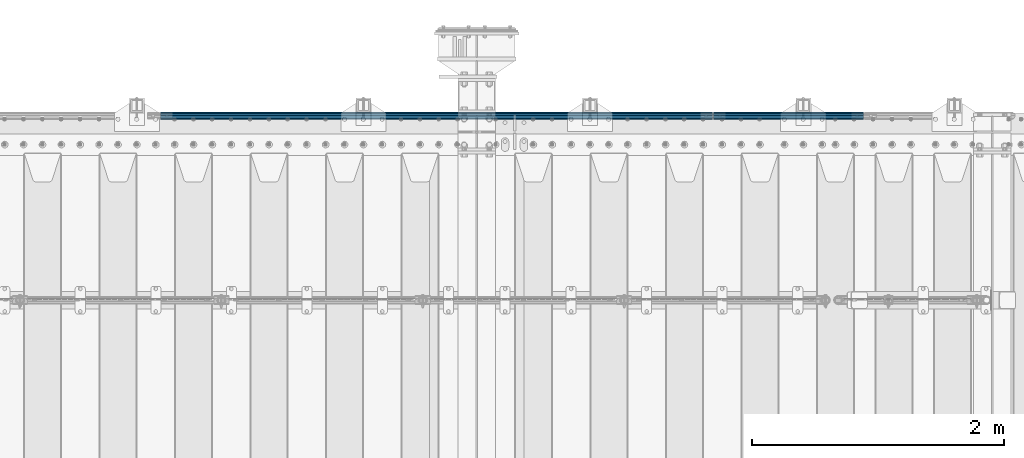
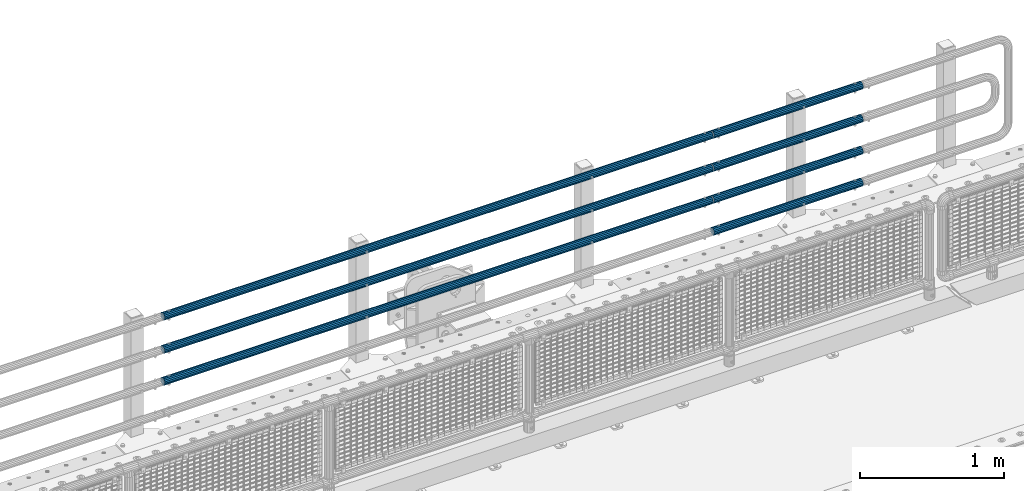
# One storey, part 108 of 208: 7 beams.
"""IFC2X3 building model written with IfcOpenShell, lengths in millimetres."""

from ifc_helpers import new_model, si_unit, frame, origin_with_axes, place, context, subcontext, project, spatial, faceted_brep, material, type_object, element, save


model = new_model("IFC2X3")

# Units and contexts
model_context = context("Model", 3, precision=1e-05, world=origin_with_axes())
body_context = subcontext(model_context, "Body", "Model", "MODEL_VIEW")
ifc_project = project(units=[si_unit("LENGTHUNIT", "METRE", prefix="MILLI"), si_unit("AREAUNIT", "SQUARE_METRE"), si_unit("VOLUMEUNIT", "CUBIC_METRE"), si_unit("MASSUNIT", "GRAM", prefix="KILO"), si_unit("TIMEUNIT", "SECOND"), si_unit("PLANEANGLEUNIT", "RADIAN"), si_unit("SOLIDANGLEUNIT", "STERADIAN"), si_unit("THERMODYNAMICTEMPERATUREUNIT", "DEGREE_CELSIUS"), si_unit("LUMINOUSINTENSITYUNIT", "LUMEN")], contexts=[model_context])

# Site, building, storey
site_placement = place(None, origin_with_axes())
site = spatial("IfcSite", under=ifc_project, at=site_placement, CompositionType="ELEMENT")
building_placement = place(site_placement, origin_with_axes())
building = spatial("IfcBuilding", under=site, at=building_placement, Name="Standard", CompositionType="ELEMENT")
storey_placement = place(building_placement, origin_with_axes())
storey = spatial("IfcBuildingStorey", under=building, at=storey_placement, Name="Undefined", CompositionType="ELEMENT", Elevation=0.0)

# Beams
ifc_material = material()
beam_type = type_object("IfcBeamType", PredefinedType="NOTDEFINED")
beam_1_placement = place(storey_placement, frame((-28328.0000000001, 6129.85000000019, 420.149999999728), z_axis=(0.0, 0.0, -1.0), x_axis=(-1.0, 0.0, 0.0)))
element("IfcBeam", 1, at=beam_1_placement, inside=storey, type_object=beam_type, material=ifc_material, context=body_context, shape_type="Brep", body=[
    faceted_brep([(0.0, -26.5500000000002, 0.0), (0.0, -24.5290015881747, 10.1602451292931), (4384.0, -24.5290015881747, 10.1602451292931), (4384.0, -26.5500000000002, 0.0), (0.0, -18.7736850405026, 18.7736850405028), (4384.0, -18.7736850405026, 18.7736850405028), (0.0, -10.1602451292929, 24.5290015881747), (4384.0, -10.1602451292929, 24.5290015881747), (0.0, 0.0, 26.55), (4384.0, 0.0, 26.55), (0.0, 10.1602451292929, 24.5290015881747), (4384.0, 10.1602451292929, 24.5290015881747), (0.0, 18.7736850405026, 18.7736850405028), (4384.0, 18.7736850405026, 18.7736850405028), (0.0, 24.5290015881747, 10.1602451292931), (4384.0, 24.5290015881747, 10.1602451292931), (0.0, 26.5500000000002, 0.0), (4384.0, 26.5500000000002, 0.0), (0.0, 24.5290015881747, -10.1602451292931), (4384.0, 24.5290015881747, -10.1602451292931), (0.0, 18.7736850405026, -18.7736850405028), (4384.0, 18.7736850405026, -18.7736850405028), (0.0, 10.1602451292929, -24.5290015881747), (4384.0, 10.1602451292929, -24.5290015881747), (0.0, 0.0, -26.55), (4384.0, 0.0, -26.55), (0.0, -10.1602451292929, -24.5290015881747), (4384.0, -10.1602451292929, -24.5290015881747), (0.0, -18.7736850405026, -18.7736850405028), (4384.0, -18.7736850405026, -18.7736850405028), (0.0, -24.5290015881747, -10.1602451292931), (4384.0, -24.5290015881747, -10.1602451292931), (0.0, -30.1499999999996, 0.0), (0.0, -27.8549679052148, -11.5379054858058), (4384.0, -27.8549679052148, -11.5379054858075), (4384.0, -30.1499999999996, 0.0), (0.0, -21.3192694527743, -21.3192694527752), (4384.0, -21.3192694527743, -21.3192694527744), (0.0, -11.5379054858076, -27.8549679052157), (4384.0, -11.5379054858076, -27.8549679052153), (0.0, 0.0, -30.1500000000015), (4384.0, 0.0, -30.15), (0.0, 11.5379054858076, -27.8549679052157), (4384.0, 11.5379054858076, -27.8549679052153), (0.0, 21.3192694527743, -21.3192694527752), (4384.0, 21.3192694527743, -21.3192694527744), (0.0, 27.8549679052157, -11.5379054858058), (4384.0, 27.8549679052157, -11.5379054858074), (0.0, 30.1499999999996, 0.0), (4384.0, 30.1499999999996, 0.0), (0.0, 27.8549679052157, 11.5379054858058), (4384.0, 27.8549679052157, 11.5379054858075), (0.0, 21.3192694527743, 21.3192694527752), (4384.0, 21.3192694527743, 21.3192694527744), (0.0, 11.5379054858076, 27.8549679052157), (4384.0, 11.5379054858076, 27.8549679052153), (0.0, 0.0, 30.1500000000015), (4384.0, 0.0, 30.15), (0.0, -11.5379054858076, 27.8549679052157), (4384.0, -11.5379054858076, 27.8549679052153), (0.0, -21.3192694527743, 21.3192694527752), (4384.0, -21.3192694527743, 21.3192694527744), (0.0, -27.8549679052157, 11.5379054858058), (4384.0, -27.8549679052157, 11.5379054858075)], [[[0, 1, 2, 3]], [[1, 4, 5, 2]], [[4, 6, 7, 5]], [[6, 8, 9, 7]], [[8, 10, 11, 9]], [[10, 12, 13, 11]], [[12, 14, 15, 13]], [[14, 16, 17, 15]], [[16, 18, 19, 17]], [[18, 20, 21, 19]], [[20, 22, 23, 21]], [[22, 24, 25, 23]], [[24, 26, 27, 25]], [[26, 28, 29, 27]], [[28, 30, 31, 29]], [[30, 0, 3, 31]], [[32, 33, 34, 35]], [[33, 36, 37, 34]], [[36, 38, 39, 37]], [[38, 40, 41, 39]], [[40, 42, 43, 41]], [[42, 44, 45, 43]], [[44, 46, 47, 45]], [[46, 48, 49, 47]], [[48, 50, 51, 49]], [[50, 52, 53, 51]], [[52, 54, 55, 53]], [[54, 56, 57, 55]], [[56, 58, 59, 57]], [[58, 60, 61, 59]], [[60, 62, 63, 61]], [[62, 32, 35, 63]], [[37, 39, 41, 43, 45, 47, 49, 51, 53, 55, 57, 59, 61, 63, 35, 34], [5, 7, 9, 11, 13, 15, 17, 19, 21, 23, 25, 27, 29, 31, 3, 2]], [[62, 60, 58, 56, 54, 52, 50, 48, 46, 44, 42, 40, 38, 36, 33, 32], [30, 28, 26, 24, 22, 20, 18, 16, 14, 12, 10, 8, 6, 4, 1, 0]]]),
])
beam_2_placement = place(storey_placement, frame((-28328.0000000001, 6129.85000000019, 969.849999999725), z_axis=(0.0, 0.0, -1.0), x_axis=(-1.0, 0.0, 0.0)))
element("IfcBeam", 2, at=beam_2_placement, inside=storey, type_object=beam_type, material=ifc_material, context=body_context, shape_type="Brep", body=[
    faceted_brep([(0.0, -26.5500000000002, 0.0), (0.0, -24.5290015881747, 10.1602451292931), (4384.0, -24.5290015881747, 10.1602451292931), (4384.0, -26.5500000000002, 0.0), (0.0, -18.7736850405026, 18.7736850405028), (4384.0, -18.7736850405026, 18.7736850405028), (0.0, -10.1602451292929, 24.5290015881747), (4384.0, -10.1602451292929, 24.5290015881747), (0.0, 0.0, 26.55), (4384.0, 0.0, 26.55), (0.0, 10.1602451292929, 24.5290015881747), (4384.0, 10.1602451292929, 24.5290015881747), (0.0, 18.7736850405026, 18.7736850405028), (4384.0, 18.7736850405026, 18.7736850405028), (0.0, 24.5290015881747, 10.1602451292931), (4384.0, 24.5290015881747, 10.1602451292931), (0.0, 26.5500000000002, 0.0), (4384.0, 26.5500000000002, 0.0), (0.0, 24.5290015881747, -10.1602451292931), (4384.0, 24.5290015881747, -10.1602451292931), (0.0, 18.7736850405026, -18.7736850405028), (4384.0, 18.7736850405026, -18.7736850405028), (0.0, 10.1602451292929, -24.5290015881747), (4384.0, 10.1602451292929, -24.5290015881747), (0.0, 0.0, -26.55), (4384.0, 0.0, -26.55), (0.0, -10.1602451292929, -24.5290015881747), (4384.0, -10.1602451292929, -24.5290015881747), (0.0, -18.7736850405026, -18.7736850405028), (4384.0, -18.7736850405026, -18.7736850405028), (0.0, -24.5290015881747, -10.1602451292931), (4384.0, -24.5290015881747, -10.1602451292931), (0.0, -30.1499999999996, 0.0), (0.0, -27.8549679052148, -11.5379054858058), (4384.0, -27.8549679052148, -11.5379054858075), (4384.0, -30.1499999999996, 0.0), (0.0, -21.3192694527743, -21.3192694527752), (4384.0, -21.3192694527743, -21.3192694527744), (0.0, -11.5379054858076, -27.8549679052157), (4384.0, -11.5379054858076, -27.8549679052153), (0.0, 0.0, -30.1500000000015), (4384.0, 0.0, -30.15), (0.0, 11.5379054858076, -27.8549679052157), (4384.0, 11.5379054858076, -27.8549679052153), (0.0, 21.3192694527743, -21.3192694527752), (4384.0, 21.3192694527743, -21.3192694527744), (0.0, 27.8549679052157, -11.5379054858058), (4384.0, 27.8549679052157, -11.5379054858074), (0.0, 30.1499999999996, 0.0), (4384.0, 30.1499999999996, 0.0), (0.0, 27.8549679052157, 11.5379054858058), (4384.0, 27.8549679052157, 11.5379054858075), (0.0, 21.3192694527743, 21.3192694527752), (4384.0, 21.3192694527743, 21.3192694527744), (0.0, 11.5379054858076, 27.8549679052157), (4384.0, 11.5379054858076, 27.8549679052153), (0.0, 0.0, 30.1500000000015), (4384.0, 0.0, 30.15), (0.0, -11.5379054858076, 27.8549679052157), (4384.0, -11.5379054858076, 27.8549679052153), (0.0, -21.3192694527743, 21.3192694527752), (4384.0, -21.3192694527743, 21.3192694527744), (0.0, -27.8549679052157, 11.5379054858058), (4384.0, -27.8549679052157, 11.5379054858075)], [[[0, 1, 2, 3]], [[1, 4, 5, 2]], [[4, 6, 7, 5]], [[6, 8, 9, 7]], [[8, 10, 11, 9]], [[10, 12, 13, 11]], [[12, 14, 15, 13]], [[14, 16, 17, 15]], [[16, 18, 19, 17]], [[18, 20, 21, 19]], [[20, 22, 23, 21]], [[22, 24, 25, 23]], [[24, 26, 27, 25]], [[26, 28, 29, 27]], [[28, 30, 31, 29]], [[30, 0, 3, 31]], [[32, 33, 34, 35]], [[33, 36, 37, 34]], [[36, 38, 39, 37]], [[38, 40, 41, 39]], [[40, 42, 43, 41]], [[42, 44, 45, 43]], [[44, 46, 47, 45]], [[46, 48, 49, 47]], [[48, 50, 51, 49]], [[50, 52, 53, 51]], [[52, 54, 55, 53]], [[54, 56, 57, 55]], [[56, 58, 59, 57]], [[58, 60, 61, 59]], [[60, 62, 63, 61]], [[62, 32, 35, 63]], [[37, 39, 41, 43, 45, 47, 49, 51, 53, 55, 57, 59, 61, 63, 35, 34], [5, 7, 9, 11, 13, 15, 17, 19, 21, 23, 25, 27, 29, 31, 3, 2]], [[62, 60, 58, 56, 54, 52, 50, 48, 46, 44, 42, 40, 38, 36, 33, 32], [30, 28, 26, 24, 22, 20, 18, 16, 14, 12, 10, 8, 6, 4, 1, 0]]]),
])
beam_3_placement = place(storey_placement, frame((-28317.9999999999, 6129.8499999996, 419.849999999725), z_axis=(0.0, -1.0, 0.0), x_axis=(1.0, 0.0, 0.0)))
element("IfcBeam", 3, at=beam_3_placement, inside=storey, type_object=beam_type, material=ifc_material, context=body_context, shape_type="Brep", body=[
    faceted_brep([(0.0, -26.5500000000002, 0.0), (0.0, -24.5290015881747, 10.1602451292931), (1190.0, -24.5290015881747, 10.1602451292929), (1190.0, -26.55, 0.0), (0.0, -18.7736850405026, 18.7736850405028), (1190.0, -18.7736850405028, 18.7736850405026), (0.0, -10.1602451292929, 24.5290015881747), (1190.0, -10.1602451292931, 24.5290015881747), (0.0, 0.0, 26.55), (1190.0, 0.0, 26.5500000000002), (0.0, 10.1602451292929, 24.5290015881747), (1190.0, 10.1602451292932, 24.5290015881747), (0.0, 18.7736850405026, 18.7736850405028), (1190.0, 18.7736850405029, 18.7736850405026), (0.0, 24.5290015881747, 10.1602451292931), (1190.0, 24.5290015881747, 10.1602451292929), (0.0, 26.5500000000002, 0.0), (1190.0, 26.55, 0.0), (0.0, 24.5290015881747, -10.1602451292931), (1190.0, 24.5290015881747, -10.1602451292929), (0.0, 18.7736850405026, -18.7736850405028), (1190.0, 18.7736850405028, -18.7736850405026), (0.0, 10.1602451292929, -24.5290015881747), (1190.0, 10.1602451292931, -24.5290015881747), (0.0, 0.0, -26.55), (1190.0, 0.0, -26.5500000000002), (0.0, -10.1602451292929, -24.5290015881747), (1190.0, -10.1602451292931, -24.5290015881747), (0.0, -18.7736850405026, -18.7736850405028), (1190.0, -18.7736850405028, -18.7736850405026), (0.0, -24.5290015881747, -10.1602451292931), (1190.0, -24.5290015881747, -10.1602451292929), (0.0, -30.1499999999996, 0.0), (0.0, -27.8549679052148, -11.5379054858058), (1190.0, -27.8549679052153, -11.5379054858076), (1190.0, -30.15, 0.0), (0.0, -21.3192694527743, -21.3192694527752), (1190.0, -21.3192694527744, -21.3192694527743), (0.0, -11.5379054858076, -27.8549679052157), (1190.0, -11.5379054858075, -27.8549679052148), (0.0, 0.0, -30.1500000000015), (1190.0, 0.0, -30.1499999999996), (0.0, 11.5379054858076, -27.8549679052157), (1190.0, 11.5379054858075, -27.8549679052148), (0.0, 21.3192694527743, -21.3192694527752), (1190.0, 21.3192694527744, -21.3192694527743), (0.0, 27.8549679052157, -11.5379054858058), (1190.0, 27.8549679052153, -11.5379054858076), (0.0, 30.1499999999996, 0.0), (1190.0, 30.15, 0.0), (0.0, 27.8549679052157, 11.5379054858058), (1190.0, 27.8549679052153, 11.5379054858076), (0.0, 21.3192694527743, 21.3192694527752), (1190.0, 21.3192694527744, 21.3192694527743), (0.0, 11.5379054858076, 27.8549679052157), (1190.0, 11.5379054858075, 27.8549679052157), (0.0, 0.0, 30.1500000000015), (1190.0, 0.0, 30.1499999999996), (0.0, -11.5379054858076, 27.8549679052157), (1190.0, -11.5379054858075, 27.8549679052157), (0.0, -21.3192694527743, 21.3192694527752), (1190.0, -21.3192694527744, 21.3192694527743), (0.0, -27.8549679052157, 11.5379054858058), (1190.0, -27.8549679052153, 11.5379054858076)], [[[0, 1, 2, 3]], [[1, 4, 5, 2]], [[4, 6, 7, 5]], [[6, 8, 9, 7]], [[8, 10, 11, 9]], [[10, 12, 13, 11]], [[12, 14, 15, 13]], [[14, 16, 17, 15]], [[16, 18, 19, 17]], [[18, 20, 21, 19]], [[20, 22, 23, 21]], [[22, 24, 25, 23]], [[24, 26, 27, 25]], [[26, 28, 29, 27]], [[28, 30, 31, 29]], [[30, 0, 3, 31]], [[32, 33, 34, 35]], [[33, 36, 37, 34]], [[36, 38, 39, 37]], [[38, 40, 41, 39]], [[40, 42, 43, 41]], [[42, 44, 45, 43]], [[44, 46, 47, 45]], [[46, 48, 49, 47]], [[48, 50, 51, 49]], [[50, 52, 53, 51]], [[52, 54, 55, 53]], [[54, 56, 57, 55]], [[56, 58, 59, 57]], [[58, 60, 61, 59]], [[60, 62, 63, 61]], [[62, 32, 35, 63]], [[37, 39, 41, 43, 45, 47, 49, 51, 53, 55, 57, 59, 61, 63, 35, 34], [5, 7, 9, 11, 13, 15, 17, 19, 21, 23, 25, 27, 29, 31, 3, 2]], [[62, 60, 58, 56, 54, 52, 50, 48, 46, 44, 42, 40, 38, 36, 33, 32], [30, 28, 26, 24, 22, 20, 18, 16, 14, 12, 10, 8, 6, 4, 1, 0]]]),
])
beam_4_placement = place(storey_placement, frame((-28317.9999999999, 6129.8499999996, 149.549999999726), z_axis=(0.0, -1.0, 0.0), x_axis=(1.0, 0.0, 0.0)))
element("IfcBeam", 4, at=beam_4_placement, inside=storey, type_object=beam_type, material=ifc_material, context=body_context, shape_type="Brep", body=[
    faceted_brep([(0.0, -26.5500000000002, 0.0), (0.0, -24.5290015881747, 10.1602451292931), (1190.0, -24.5290015881747, 10.1602451292929), (1190.0, -26.55, 0.0), (0.0, -18.7736850405026, 18.7736850405028), (1190.0, -18.7736850405028, 18.7736850405026), (0.0, -10.1602451292929, 24.5290015881747), (1190.0, -10.1602451292931, 24.5290015881747), (0.0, 0.0, 26.55), (1190.0, 0.0, 26.5500000000002), (0.0, 10.1602451292929, 24.5290015881747), (1190.0, 10.1602451292932, 24.5290015881747), (0.0, 18.7736850405026, 18.7736850405028), (1190.0, 18.7736850405029, 18.7736850405026), (0.0, 24.5290015881747, 10.1602451292931), (1190.0, 24.5290015881747, 10.1602451292929), (0.0, 26.5500000000002, 0.0), (1190.0, 26.55, 0.0), (0.0, 24.5290015881747, -10.1602451292931), (1190.0, 24.5290015881747, -10.1602451292929), (0.0, 18.7736850405026, -18.7736850405028), (1190.0, 18.7736850405028, -18.7736850405026), (0.0, 10.1602451292929, -24.5290015881747), (1190.0, 10.1602451292931, -24.5290015881747), (0.0, 0.0, -26.55), (1190.0, 0.0, -26.5500000000002), (0.0, -10.1602451292929, -24.5290015881747), (1190.0, -10.1602451292931, -24.5290015881747), (0.0, -18.7736850405026, -18.7736850405028), (1190.0, -18.7736850405028, -18.7736850405026), (0.0, -24.5290015881747, -10.1602451292931), (1190.0, -24.5290015881747, -10.1602451292929), (0.0, -30.1499999999996, 0.0), (0.0, -27.8549679052148, -11.5379054858058), (1190.0, -27.8549679052153, -11.5379054858076), (1190.0, -30.15, 0.0), (0.0, -21.3192694527743, -21.3192694527752), (1190.0, -21.3192694527744, -21.3192694527743), (0.0, -11.5379054858076, -27.8549679052157), (1190.0, -11.5379054858075, -27.8549679052148), (0.0, 0.0, -30.1500000000015), (1190.0, 0.0, -30.1499999999996), (0.0, 11.5379054858076, -27.8549679052157), (1190.0, 11.5379054858075, -27.8549679052148), (0.0, 21.3192694527743, -21.3192694527752), (1190.0, 21.3192694527744, -21.3192694527743), (0.0, 27.8549679052157, -11.5379054858058), (1190.0, 27.8549679052153, -11.5379054858076), (0.0, 30.1499999999996, 0.0), (1190.0, 30.15, 0.0), (0.0, 27.8549679052157, 11.5379054858058), (1190.0, 27.8549679052153, 11.5379054858076), (0.0, 21.3192694527743, 21.3192694527752), (1190.0, 21.3192694527744, 21.3192694527743), (0.0, 11.5379054858076, 27.8549679052157), (1190.0, 11.5379054858075, 27.8549679052157), (0.0, 0.0, 30.1500000000015), (1190.0, 0.0, 30.1499999999996), (0.0, -11.5379054858076, 27.8549679052157), (1190.0, -11.5379054858075, 27.8549679052157), (0.0, -21.3192694527743, 21.3192694527752), (1190.0, -21.3192694527744, 21.3192694527743), (0.0, -27.8549679052157, 11.5379054858058), (1190.0, -27.8549679052153, 11.5379054858076)], [[[0, 1, 2, 3]], [[1, 4, 5, 2]], [[4, 6, 7, 5]], [[6, 8, 9, 7]], [[8, 10, 11, 9]], [[10, 12, 13, 11]], [[12, 14, 15, 13]], [[14, 16, 17, 15]], [[16, 18, 19, 17]], [[18, 20, 21, 19]], [[20, 22, 23, 21]], [[22, 24, 25, 23]], [[24, 26, 27, 25]], [[26, 28, 29, 27]], [[28, 30, 31, 29]], [[30, 0, 3, 31]], [[32, 33, 34, 35]], [[33, 36, 37, 34]], [[36, 38, 39, 37]], [[38, 40, 41, 39]], [[40, 42, 43, 41]], [[42, 44, 45, 43]], [[44, 46, 47, 45]], [[46, 48, 49, 47]], [[48, 50, 51, 49]], [[50, 52, 53, 51]], [[52, 54, 55, 53]], [[54, 56, 57, 55]], [[56, 58, 59, 57]], [[58, 60, 61, 59]], [[60, 62, 63, 61]], [[62, 32, 35, 63]], [[37, 39, 41, 43, 45, 47, 49, 51, 53, 55, 57, 59, 61, 63, 35, 34], [5, 7, 9, 11, 13, 15, 17, 19, 21, 23, 25, 27, 29, 31, 3, 2]], [[62, 60, 58, 56, 54, 52, 50, 48, 46, 44, 42, 40, 38, 36, 33, 32], [30, 28, 26, 24, 22, 20, 18, 16, 14, 12, 10, 8, 6, 4, 1, 0]]]),
])
beam_5_placement = place(storey_placement, frame((-28317.9999999999, 6129.8499999996, 969.549999999726), z_axis=(0.0, -1.0, 0.0), x_axis=(1.0, 0.0, 0.0)))
element("IfcBeam", 5, at=beam_5_placement, inside=storey, type_object=beam_type, material=ifc_material, context=body_context, shape_type="Brep", body=[
    faceted_brep([(0.0, -26.5500000000002, 0.0), (0.0, -24.5290015881747, 10.1602451292931), (1190.0, -24.5290015881747, 10.1602451292929), (1190.0, -26.55, 0.0), (0.0, -18.7736850405026, 18.7736850405028), (1190.0, -18.7736850405028, 18.7736850405026), (0.0, -10.1602451292929, 24.5290015881747), (1190.0, -10.1602451292931, 24.5290015881747), (0.0, 0.0, 26.55), (1190.0, 0.0, 26.5500000000002), (0.0, 10.1602451292929, 24.5290015881747), (1190.0, 10.1602451292932, 24.5290015881747), (0.0, 18.7736850405026, 18.7736850405028), (1190.0, 18.7736850405029, 18.7736850405026), (0.0, 24.5290015881747, 10.1602451292931), (1190.0, 24.5290015881747, 10.1602451292929), (0.0, 26.5500000000002, 0.0), (1190.0, 26.55, 0.0), (0.0, 24.5290015881747, -10.1602451292931), (1190.0, 24.5290015881747, -10.1602451292929), (0.0, 18.7736850405026, -18.7736850405028), (1190.0, 18.7736850405028, -18.7736850405026), (0.0, 10.1602451292929, -24.5290015881747), (1190.0, 10.1602451292931, -24.5290015881747), (0.0, 0.0, -26.55), (1190.0, 0.0, -26.5500000000002), (0.0, -10.1602451292929, -24.5290015881747), (1190.0, -10.1602451292931, -24.5290015881747), (0.0, -18.7736850405026, -18.7736850405028), (1190.0, -18.7736850405028, -18.7736850405026), (0.0, -24.5290015881747, -10.1602451292931), (1190.0, -24.5290015881747, -10.1602451292929), (0.0, -30.1499999999996, 0.0), (0.0, -27.8549679052148, -11.5379054858058), (1190.0, -27.8549679052153, -11.5379054858076), (1190.0, -30.15, 0.0), (0.0, -21.3192694527743, -21.3192694527752), (1190.0, -21.3192694527744, -21.3192694527743), (0.0, -11.5379054858076, -27.8549679052157), (1190.0, -11.5379054858075, -27.8549679052148), (0.0, 0.0, -30.1500000000015), (1190.0, 0.0, -30.1499999999996), (0.0, 11.5379054858076, -27.8549679052157), (1190.0, 11.5379054858075, -27.8549679052148), (0.0, 21.3192694527743, -21.3192694527752), (1190.0, 21.3192694527744, -21.3192694527743), (0.0, 27.8549679052157, -11.5379054858058), (1190.0, 27.8549679052153, -11.5379054858076), (0.0, 30.1499999999996, 0.0), (1190.0, 30.15, 0.0), (0.0, 27.8549679052157, 11.5379054858058), (1190.0, 27.8549679052153, 11.5379054858076), (0.0, 21.3192694527743, 21.3192694527752), (1190.0, 21.3192694527744, 21.3192694527743), (0.0, 11.5379054858076, 27.8549679052157), (1190.0, 11.5379054858075, 27.8549679052157), (0.0, 0.0, 30.1500000000015), (1190.0, 0.0, 30.1499999999996), (0.0, -11.5379054858076, 27.8549679052157), (1190.0, -11.5379054858075, 27.8549679052157), (0.0, -21.3192694527743, 21.3192694527752), (1190.0, -21.3192694527744, 21.3192694527743), (0.0, -27.8549679052157, 11.5379054858058), (1190.0, -27.8549679052153, 11.5379054858076)], [[[0, 1, 2, 3]], [[1, 4, 5, 2]], [[4, 6, 7, 5]], [[6, 8, 9, 7]], [[8, 10, 11, 9]], [[10, 12, 13, 11]], [[12, 14, 15, 13]], [[14, 16, 17, 15]], [[16, 18, 19, 17]], [[18, 20, 21, 19]], [[20, 22, 23, 21]], [[22, 24, 25, 23]], [[24, 26, 27, 25]], [[26, 28, 29, 27]], [[28, 30, 31, 29]], [[30, 0, 3, 31]], [[32, 33, 34, 35]], [[33, 36, 37, 34]], [[36, 38, 39, 37]], [[38, 40, 41, 39]], [[40, 42, 43, 41]], [[42, 44, 45, 43]], [[44, 46, 47, 45]], [[46, 48, 49, 47]], [[48, 50, 51, 49]], [[50, 52, 53, 51]], [[52, 54, 55, 53]], [[54, 56, 57, 55]], [[56, 58, 59, 57]], [[58, 60, 61, 59]], [[60, 62, 63, 61]], [[62, 32, 35, 63]], [[37, 39, 41, 43, 45, 47, 49, 51, 53, 55, 57, 59, 61, 63, 35, 34], [5, 7, 9, 11, 13, 15, 17, 19, 21, 23, 25, 27, 29, 31, 3, 2]], [[62, 60, 58, 56, 54, 52, 50, 48, 46, 44, 42, 40, 38, 36, 33, 32], [30, 28, 26, 24, 22, 20, 18, 16, 14, 12, 10, 8, 6, 4, 1, 0]]]),
])
beam_6_placement = place(storey_placement, frame((-28317.9999999999, 6129.8499999996, 689.549999999726), z_axis=(0.0, -1.0, 0.0), x_axis=(1.0, 0.0, 0.0)))
element("IfcBeam", 6, at=beam_6_placement, inside=storey, type_object=beam_type, material=ifc_material, context=body_context, shape_type="Brep", body=[
    faceted_brep([(0.0, -26.5500000000002, 0.0), (0.0, -24.5290015881747, 10.1602451292931), (1190.0, -24.5290015881747, 10.1602451292929), (1190.0, -26.55, 0.0), (0.0, -18.7736850405026, 18.7736850405028), (1190.0, -18.7736850405028, 18.7736850405026), (0.0, -10.1602451292929, 24.5290015881747), (1190.0, -10.1602451292931, 24.5290015881747), (0.0, 0.0, 26.55), (1190.0, 0.0, 26.5500000000002), (0.0, 10.1602451292929, 24.5290015881747), (1190.0, 10.1602451292932, 24.5290015881747), (0.0, 18.7736850405026, 18.7736850405028), (1190.0, 18.7736850405029, 18.7736850405026), (0.0, 24.5290015881747, 10.1602451292931), (1190.0, 24.5290015881747, 10.1602451292929), (0.0, 26.5500000000002, 0.0), (1190.0, 26.55, 0.0), (0.0, 24.5290015881747, -10.1602451292931), (1190.0, 24.5290015881747, -10.1602451292929), (0.0, 18.7736850405026, -18.7736850405028), (1190.0, 18.7736850405028, -18.7736850405026), (0.0, 10.1602451292929, -24.5290015881747), (1190.0, 10.1602451292931, -24.5290015881747), (0.0, 0.0, -26.55), (1190.0, 0.0, -26.5500000000002), (0.0, -10.1602451292929, -24.5290015881747), (1190.0, -10.1602451292931, -24.5290015881747), (0.0, -18.7736850405026, -18.7736850405028), (1190.0, -18.7736850405028, -18.7736850405026), (0.0, -24.5290015881747, -10.1602451292931), (1190.0, -24.5290015881747, -10.1602451292929), (0.0, -30.1499999999996, 0.0), (0.0, -27.8549679052148, -11.5379054858058), (1190.0, -27.8549679052153, -11.5379054858076), (1190.0, -30.15, 0.0), (0.0, -21.3192694527743, -21.3192694527752), (1190.0, -21.3192694527744, -21.3192694527743), (0.0, -11.5379054858076, -27.8549679052157), (1190.0, -11.5379054858075, -27.8549679052148), (0.0, 0.0, -30.1500000000015), (1190.0, 0.0, -30.1499999999996), (0.0, 11.5379054858076, -27.8549679052157), (1190.0, 11.5379054858075, -27.8549679052148), (0.0, 21.3192694527743, -21.3192694527752), (1190.0, 21.3192694527744, -21.3192694527743), (0.0, 27.8549679052157, -11.5379054858058), (1190.0, 27.8549679052153, -11.5379054858076), (0.0, 30.1499999999996, 0.0), (1190.0, 30.15, 0.0), (0.0, 27.8549679052157, 11.5379054858058), (1190.0, 27.8549679052153, 11.5379054858076), (0.0, 21.3192694527743, 21.3192694527752), (1190.0, 21.3192694527744, 21.3192694527743), (0.0, 11.5379054858076, 27.8549679052157), (1190.0, 11.5379054858075, 27.8549679052157), (0.0, 0.0, 30.1500000000015), (1190.0, 0.0, 30.1499999999996), (0.0, -11.5379054858076, 27.8549679052157), (1190.0, -11.5379054858075, 27.8549679052157), (0.0, -21.3192694527743, 21.3192694527752), (1190.0, -21.3192694527744, 21.3192694527743), (0.0, -27.8549679052157, 11.5379054858058), (1190.0, -27.8549679052153, 11.5379054858076)], [[[0, 1, 2, 3]], [[1, 4, 5, 2]], [[4, 6, 7, 5]], [[6, 8, 9, 7]], [[8, 10, 11, 9]], [[10, 12, 13, 11]], [[12, 14, 15, 13]], [[14, 16, 17, 15]], [[16, 18, 19, 17]], [[18, 20, 21, 19]], [[20, 22, 23, 21]], [[22, 24, 25, 23]], [[24, 26, 27, 25]], [[26, 28, 29, 27]], [[28, 30, 31, 29]], [[30, 0, 3, 31]], [[32, 33, 34, 35]], [[33, 36, 37, 34]], [[36, 38, 39, 37]], [[38, 40, 41, 39]], [[40, 42, 43, 41]], [[42, 44, 45, 43]], [[44, 46, 47, 45]], [[46, 48, 49, 47]], [[48, 50, 51, 49]], [[50, 52, 53, 51]], [[52, 54, 55, 53]], [[54, 56, 57, 55]], [[56, 58, 59, 57]], [[58, 60, 61, 59]], [[60, 62, 63, 61]], [[62, 32, 35, 63]], [[37, 39, 41, 43, 45, 47, 49, 51, 53, 55, 57, 59, 61, 63, 35, 34], [5, 7, 9, 11, 13, 15, 17, 19, 21, 23, 25, 27, 29, 31, 3, 2]], [[62, 60, 58, 56, 54, 52, 50, 48, 46, 44, 42, 40, 38, 36, 33, 32], [30, 28, 26, 24, 22, 20, 18, 16, 14, 12, 10, 8, 6, 4, 1, 0]]]),
])
beam_7_placement = place(storey_placement, frame((-28328.0000000001, 6129.85000000019, 689.849999999725), z_axis=(0.0, 0.0, -1.0), x_axis=(-1.0, 0.0, 0.0)))
element("IfcBeam", 7, at=beam_7_placement, inside=storey, type_object=beam_type, material=ifc_material, context=body_context, shape_type="Brep", body=[
    faceted_brep([(0.0, -26.5500000000002, 0.0), (0.0, -24.5290015881747, 10.1602451292931), (4384.0, -24.5290015881747, 10.1602451292931), (4384.0, -26.5500000000002, 0.0), (0.0, -18.7736850405026, 18.7736850405028), (4384.0, -18.7736850405026, 18.7736850405028), (0.0, -10.1602451292929, 24.5290015881747), (4384.0, -10.1602451292929, 24.5290015881747), (0.0, 0.0, 26.55), (4384.0, 0.0, 26.55), (0.0, 10.1602451292929, 24.5290015881747), (4384.0, 10.1602451292929, 24.5290015881747), (0.0, 18.7736850405026, 18.7736850405028), (4384.0, 18.7736850405026, 18.7736850405028), (0.0, 24.5290015881747, 10.1602451292931), (4384.0, 24.5290015881747, 10.1602451292931), (0.0, 26.5500000000002, 0.0), (4384.0, 26.5500000000002, 0.0), (0.0, 24.5290015881747, -10.1602451292931), (4384.0, 24.5290015881747, -10.1602451292931), (0.0, 18.7736850405026, -18.7736850405028), (4384.0, 18.7736850405026, -18.7736850405028), (0.0, 10.1602451292929, -24.5290015881747), (4384.0, 10.1602451292929, -24.5290015881747), (0.0, 0.0, -26.55), (4384.0, 0.0, -26.55), (0.0, -10.1602451292929, -24.5290015881747), (4384.0, -10.1602451292929, -24.5290015881747), (0.0, -18.7736850405026, -18.7736850405028), (4384.0, -18.7736850405026, -18.7736850405028), (0.0, -24.5290015881747, -10.1602451292931), (4384.0, -24.5290015881747, -10.1602451292931), (0.0, -30.1499999999996, 0.0), (0.0, -27.8549679052148, -11.5379054858058), (4384.0, -27.8549679052148, -11.5379054858075), (4384.0, -30.1499999999996, 0.0), (0.0, -21.3192694527743, -21.3192694527752), (4384.0, -21.3192694527743, -21.3192694527744), (0.0, -11.5379054858076, -27.8549679052157), (4384.0, -11.5379054858076, -27.8549679052153), (0.0, 0.0, -30.1500000000015), (4384.0, 0.0, -30.15), (0.0, 11.5379054858076, -27.8549679052157), (4384.0, 11.5379054858076, -27.8549679052153), (0.0, 21.3192694527743, -21.3192694527752), (4384.0, 21.3192694527743, -21.3192694527744), (0.0, 27.8549679052157, -11.5379054858058), (4384.0, 27.8549679052157, -11.5379054858074), (0.0, 30.1499999999996, 0.0), (4384.0, 30.1499999999996, 0.0), (0.0, 27.8549679052157, 11.5379054858058), (4384.0, 27.8549679052157, 11.5379054858075), (0.0, 21.3192694527743, 21.3192694527752), (4384.0, 21.3192694527743, 21.3192694527744), (0.0, 11.5379054858076, 27.8549679052157), (4384.0, 11.5379054858076, 27.8549679052153), (0.0, 0.0, 30.1500000000015), (4384.0, 0.0, 30.15), (0.0, -11.5379054858076, 27.8549679052157), (4384.0, -11.5379054858076, 27.8549679052153), (0.0, -21.3192694527743, 21.3192694527752), (4384.0, -21.3192694527743, 21.3192694527744), (0.0, -27.8549679052157, 11.5379054858058), (4384.0, -27.8549679052157, 11.5379054858075)], [[[0, 1, 2, 3]], [[1, 4, 5, 2]], [[4, 6, 7, 5]], [[6, 8, 9, 7]], [[8, 10, 11, 9]], [[10, 12, 13, 11]], [[12, 14, 15, 13]], [[14, 16, 17, 15]], [[16, 18, 19, 17]], [[18, 20, 21, 19]], [[20, 22, 23, 21]], [[22, 24, 25, 23]], [[24, 26, 27, 25]], [[26, 28, 29, 27]], [[28, 30, 31, 29]], [[30, 0, 3, 31]], [[32, 33, 34, 35]], [[33, 36, 37, 34]], [[36, 38, 39, 37]], [[38, 40, 41, 39]], [[40, 42, 43, 41]], [[42, 44, 45, 43]], [[44, 46, 47, 45]], [[46, 48, 49, 47]], [[48, 50, 51, 49]], [[50, 52, 53, 51]], [[52, 54, 55, 53]], [[54, 56, 57, 55]], [[56, 58, 59, 57]], [[58, 60, 61, 59]], [[60, 62, 63, 61]], [[62, 32, 35, 63]], [[37, 39, 41, 43, 45, 47, 49, 51, 53, 55, 57, 59, 61, 63, 35, 34], [5, 7, 9, 11, 13, 15, 17, 19, 21, 23, 25, 27, 29, 31, 3, 2]], [[62, 60, 58, 56, 54, 52, 50, 48, 46, 44, 42, 40, 38, 36, 33, 32], [30, 28, 26, 24, 22, 20, 18, 16, 14, 12, 10, 8, 6, 4, 1, 0]]]),
])

save(model, "model.ifc")
